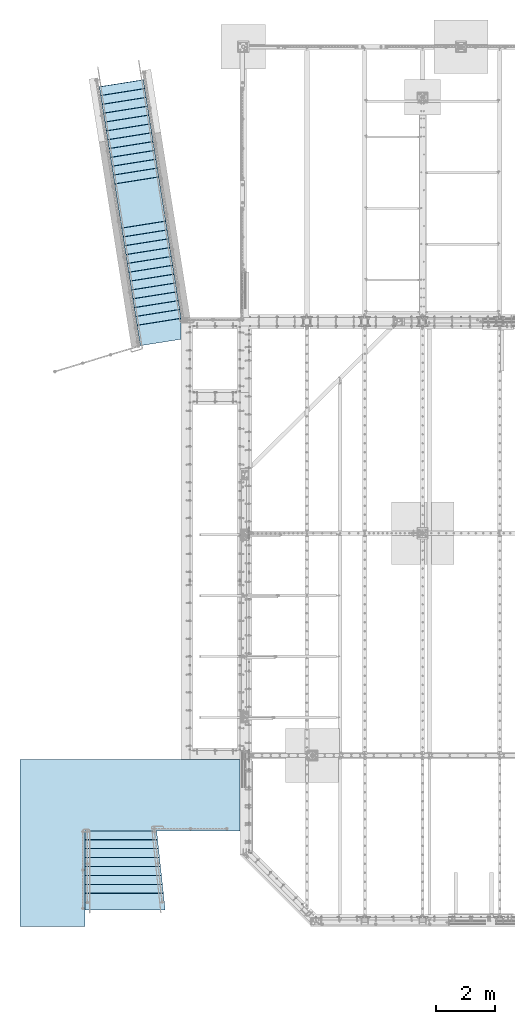
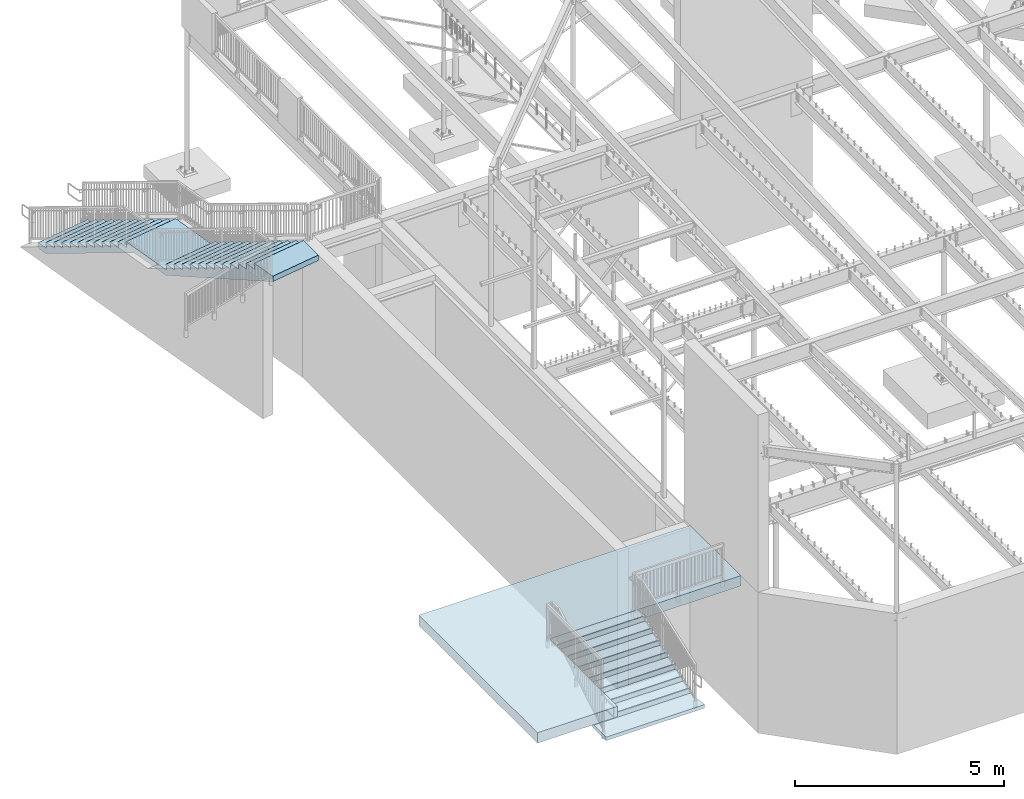
# One storey, part 829 of 975: 3 slabs.
"""IFC2X3 building model written with IfcOpenShell, lengths in millimetres."""

from ifc_helpers import new_model, si_unit, frame, origin_with_axes, place, context, subcontext, project, spatial, faceted_brep, material, type_object, element, save


model = new_model("IFC2X3")

# Units and contexts
model_context = context("Model", 3, precision=1e-05, world=origin_with_axes())
body_context = subcontext(model_context, "Body", "Model", "MODEL_VIEW")
ifc_project = project(units=[si_unit("LENGTHUNIT", "METRE", prefix="MILLI"), si_unit("AREAUNIT", "SQUARE_METRE"), si_unit("VOLUMEUNIT", "CUBIC_METRE"), si_unit("MASSUNIT", "GRAM", prefix="KILO"), si_unit("TIMEUNIT", "SECOND"), si_unit("PLANEANGLEUNIT", "RADIAN"), si_unit("SOLIDANGLEUNIT", "STERADIAN"), si_unit("THERMODYNAMICTEMPERATUREUNIT", "DEGREE_CELSIUS"), si_unit("LUMINOUSINTENSITYUNIT", "LUMEN")], contexts=[model_context])

# Site, building, storey
site_placement = place(None, origin_with_axes())
site = spatial("IfcSite", under=ifc_project, at=site_placement, CompositionType="ELEMENT")
building_placement = place(site_placement, origin_with_axes())
building = spatial("IfcBuilding", under=site, at=building_placement, Name="Undefined", CompositionType="ELEMENT")
storey_placement = place(building_placement, origin_with_axes())
storey = spatial("IfcBuildingStorey", under=building, at=storey_placement, Name="Undefined", CompositionType="ELEMENT", Elevation=0.0)

# Slabs
ifc_material = material(Name="CONCRETE/3000")
slab_type_1 = type_object("IfcSlabType", PredefinedType="NOTDEFINED")
slab_1_placement = place(storey_placement, frame((2016.12480603406, 3251.20039056697, 3962.39997558594), z_axis=(-0.999999999999998, 6.90000001668524e-08, 0.0), x_axis=(0.0, 1.0, 0.0)))
element("IfcSlab", 1, at=slab_1_placement, inside=storey, type_object=slab_type_1, material=ifc_material, Name="SLAB", PredefinedType="FLOOR", context=body_context, shape_type="Brep", body=[
    faceted_brep([(4.54747350886464e-13, -152.4, 2.27373675443232e-13), (-0.000227324977913668, -152.4, 2844.79980468751), (-0.000227324977913668, 152.4, 2844.79980468751), (4.54747350886464e-13, 152.4, 2.27373675443232e-13), (-0.000239550314290682, -152.4, 2911.74243164063), (-0.000239550314290682, 152.4, 2911.74243164063), (-0.000422655617057899, -152.4, 5283.19970703127), (-0.000422655617057899, 152.4, 5283.19970703127), (-3251.20092773405, -152.4, 5283.19921875022), (-3251.20092773405, 152.4, 5283.19921875022), (-3251.20092773391, -152.4, 7501.92285156273), (-3251.20092773391, 152.4, 7501.92285156273), (2424.57202148486, -152.4, 7501.92480468737), (2424.57202148486, 152.4, 7501.92480468737), (2424.57250976576, -152.4, 2016.12499999985), (2424.57250976576, 152.4, 2016.12499999985), (2425.69946289076, -152.4, 2016.12499999985), (2425.69946289076, 152.4, 2016.12499999985), (2425.69970703126, -152.4, -4.25188773078844e-10), (2425.69970703126, 152.4, -4.25188773078844e-10)], [[[0, 1, 2, 3]], [[1, 4, 5, 2]], [[4, 6, 7, 5]], [[6, 8, 9, 7]], [[8, 10, 11, 9]], [[10, 12, 13, 11]], [[12, 14, 15, 13]], [[14, 16, 17, 15]], [[16, 18, 19, 17]], [[18, 0, 3, 19]], [[5, 7, 9, 11, 13, 15, 17, 19, 3, 2]], [[18, 16, 14, 12, 10, 8, 6, 4, 1, 0]]]),
])
slab_type_2 = type_object("IfcSlabType", PredefinedType="NOTDEFINED")
slab_2_placement = place(storey_placement, frame((-1819.27499858123, 1143.00036444701, 2870.2), z_axis=(0.0, 0.0, -1.0), x_axis=(0.0, -1.0, 0.0)))
element("IfcSlab", 2, at=slab_2_placement, inside=storey, type_object=slab_type_2, material=ifc_material, Name="STAIR", PredefinedType="FLOOR", context=body_context, shape_type="Brep", body=[
    faceted_brep([(22.9399124926131, 1447.8, -168.686255001375), (20.3510419406048, 1447.8, -173.42106525441), (16.0299404980549, 1447.8, -176.653519614567), (10.7567768749961, 1447.8, -177.800003051758), (-304.799987792969, 1447.8, -177.800003051758), (-281.470857728083, 1447.8, -341.103955550173), (-281.860080640712, 1447.8, -346.486258341314), (-284.448951239109, 1447.8, -351.221068457464), (-288.770052641537, 1447.8, -354.453522707902), (-294.0432161735, 1447.8, -355.600006103516), (-609.599975585938, 1447.8, -355.600006103516), (-586.27087304912, 1447.8, -518.903976126535), (-586.660096770178, 1447.8, -524.286278298611), (-589.248967633653, 1447.8, -529.021087632559), (-593.570068806812, 1447.8, -532.253541256034), (-598.843231818224, 1447.8, -533.400024414062), (-914.400024414062, 1447.8, -533.400024414062), (-891.07086682111, 1447.8, -696.703959387874), (-891.46008892531, 1447.8, -702.086262798078), (-894.048959258629, 1447.8, -706.821073696431), (-898.370060890327, 1447.8, -710.053528573832), (-903.643224942838, 1447.8, -711.200012207031), (-1219.19995117188, 1447.8, -711.200012207031), (-1195.8709044884, 1447.8, -874.503955639886), (-1196.26012961073, 1447.8, -879.88625673892), (-1198.84900093367, 1447.8, -884.621064717048), (-1203.17010170943, 1447.8, -887.853517253785), (-1208.44326381856, 1447.8, -889.0), (-1524.0, 1447.8, -889.0), (-1500.67084160984, 1447.8, -1052.30399661319), (-1501.06006392962, 1447.8, -1057.68629985831), (-1503.64893433363, 1447.8, -1062.42111054807), (-1507.97003590419, 1447.8, -1065.65356525828), (-1513.24319981789, 1447.8, -1066.80004882812), (-1828.80004882812, 1447.8, -1066.80004882812), (-1805.47089287016, 1447.8, -1230.10391629805), (-1805.86011511785, 1447.8, -1235.48622109315), (-1808.44898668768, 1447.8, -1240.22103290149), (-1812.77009018458, 1447.8, -1243.45348760877), (-1818.04325599184, 1447.8, -1244.59996972142), (-2108.19995117188, 1447.8, -1244.59985351562), (-2108.19995117188, 1447.8, -1066.79992675781), (-2025.12231445312, 1447.8, -1066.80004882812), (-27.0423221588135, 1447.8, 101.599998474121), (583.815185546875, 1447.8, 101.599998474121), (583.815185546875, 1447.8, 0.0), (0.0, 1447.8, 0.0), (23.3291352637673, 1447.8, -163.303952101898), (583.815185546875, -1280.75730059277, 101.599998474121), (583.815185546875, -1280.75730059277, 0.0), (0.0, -1217.83111892056, 0.0), (23.3291352637673, -1220.34563625448, -163.303952101898), (22.9399124926131, -1220.3036841035, -168.686255001375), (20.3510419406048, -1220.02464419033, -173.42106525441), (16.0299404980549, -1219.5588967738, -176.653519614567), (10.7567768749961, -1218.99053188651, -177.800003051758), (-304.799987792969, -1184.97842875357, -177.800003051758), (-281.470857728083, -1187.49294552714, -341.103955550173), (-281.860080640712, -1187.45099336091, -346.486258341314), (-284.448951239109, -1187.17195344274, -351.221068457464), (-288.770052641537, -1186.70620603053, -354.453522707902), (-294.0432161735, -1186.13784115306, -355.600006103516), (-609.599975585938, -1152.12573858659, -355.600006103516), (-586.27087304912, -1154.64025239306, -518.903976126535), (-586.660096770178, -1154.59830013969, -524.286278298611), (-589.248967633653, -1154.31926019295, -529.021087632559), (-593.570068806812, -1153.85351280546, -532.253541256034), (-598.843231818224, -1153.2851479841, -533.400024414062), (-914.400024414062, -1119.27304184097, -533.400024414062), (-891.07086682111, -1121.78756158163, -696.703959387874), (-891.46008892531, -1121.74560950254, -702.086262798078), (-894.048959258629, -1121.46656961294, -706.821073696431), (-898.370060890327, -1121.00082217602, -710.053528573832), (-903.643224942838, -1120.43245724244, -711.200012207031), (-1219.19995117188, -1086.42035825263, -711.200012207031), (-1195.8709044884, -1088.93486603897, -874.503955639886), (-1196.26012961073, -1088.89291363457, -879.88625673892), (-1198.84900093367, -1088.61387363831, -884.621064717048), (-1203.17010170943, -1088.14812629365, -887.853517253785), (-1208.44326381856, -1087.57976156954, -889.0), (-1524.0, -1053.567661507, -889.0), (-1500.67084160984, -1056.08218133359, -1052.30399661319), (-1501.06006392962, -1056.04022923126, -1057.68629985831), (-1503.64893433363, -1055.76118933404, -1062.42111054807), (-1507.97003590419, -1055.29544190372, -1065.65356525828), (-1513.24319981789, -1054.7270769851, -1066.80004882812), (-1828.80004882812, -1020.71496476138, -1066.80004882812), (-1805.47089287016, -1023.22948432582, -1230.10391629805), (-1805.86011511785, -1023.18753223126, -1235.48622109315), (-1808.44898668768, -1022.90849220838, -1240.22103290149), (-1812.77009018458, -1022.44274457043, -1243.45348760877), (-1818.04325599184, -1021.87437944772, -1244.59996972142), (-2108.19995117188, -990.600008094722, -1244.59985351562), (-2108.19995117188, -990.600008094722, -1066.79992675781), (-2025.12231445312, -999.554483056119, -1066.80004882812), (-27.0423221588135, -1214.91637788755, 101.599998474121)], [[[0, 1, 2, 3, 4, 5, 6, 7, 8, 9, 10, 11, 12, 13, 14, 15, 16, 17, 18, 19, 20, 21, 22, 23, 24, 25, 26, 27, 28, 29, 30, 31, 32, 33, 34, 35, 36, 37, 38, 39, 40, 41, 42, 43, 44, 45, 46, 47]], [[45, 44, 48, 49]], [[46, 45, 49, 50]], [[47, 46, 50, 51]], [[0, 47, 51, 52]], [[1, 0, 52, 53]], [[2, 1, 53, 54]], [[3, 2, 54, 55]], [[4, 3, 55, 56]], [[5, 4, 56, 57]], [[6, 5, 57, 58]], [[7, 6, 58, 59]], [[8, 7, 59, 60]], [[9, 8, 60, 61]], [[10, 9, 61, 62]], [[11, 10, 62, 63]], [[12, 11, 63, 64]], [[13, 12, 64, 65]], [[14, 13, 65, 66]], [[15, 14, 66, 67]], [[16, 15, 67, 68]], [[17, 16, 68, 69]], [[18, 17, 69, 70]], [[19, 18, 70, 71]], [[20, 19, 71, 72]], [[21, 20, 72, 73]], [[22, 21, 73, 74]], [[23, 22, 74, 75]], [[24, 23, 75, 76]], [[25, 24, 76, 77]], [[26, 25, 77, 78]], [[27, 26, 78, 79]], [[28, 27, 79, 80]], [[29, 28, 80, 81]], [[30, 29, 81, 82]], [[31, 30, 82, 83]], [[32, 31, 83, 84]], [[33, 32, 84, 85]], [[34, 33, 85, 86]], [[35, 34, 86, 87]], [[36, 35, 87, 88]], [[37, 36, 88, 89]], [[38, 37, 89, 90]], [[39, 38, 90, 91]], [[40, 39, 91, 92]], [[41, 40, 92, 93]], [[42, 41, 93, 94]], [[43, 42, 94, 95]], [[44, 43, 95, 48]], [[94, 93, 92, 91, 90, 89, 88, 87, 86, 85, 84, 83, 82, 81, 80, 79, 78, 77, 76, 75, 74, 73, 72, 71, 70, 69, 68, 67, 66, 65, 64, 63, 62, 61, 60, 59, 58, 57, 56, 55, 54, 53, 52, 51, 50, 49, 48, 95]]]),
])
slab_type_3 = type_object("IfcSlabType", PredefinedType="NOTDEFINED")
slab_3_placement = place(storey_placement, frame((-747.347909321386, 20600.7344463593, 4038.60004696893), z_axis=(0.0, 0.0, -1.0), x_axis=(0.156434463962902, -0.98768834076577, 3.20000000030926e-08)))
element("IfcSlab", 3, at=slab_3_placement, inside=storey, type_object=slab_type_3, material=ifc_material, Name="STAIR", PredefinedType="FLOOR", context=body_context, shape_type="Brep", body=[
    faceted_brep([(-290.039056119542, -761.999999999877, 168.275023731918), (-295.335071312391, -761.999999999876, 169.431964500519), (-295.335071313042, 761.999999999946, 169.431964500588), (-290.0390561202, 761.999999999946, 168.275023731988), (-299.666176999308, -761.999999999875, 172.691997076068), (-299.666176999959, 761.999999999947, 172.691997076137), (-302.243265816895, -761.999999999875, 177.461158647158), (-302.243265817549, 761.999999999948, 177.461158647228), (-302.596804138157, -761.999999999875, 182.870530100508), (-302.596804138811, 761.999999999947, 182.870530100578), (-279.399932860801, -761.99999999989, 336.550018310512), (-279.399932861459, 761.999999999932, 336.550018310582), (-594.839201503801, -761.999999999839, 336.550018310512), (-594.839201504456, 761.999999999983, 336.550018310582), (-600.135215782844, -761.999999999839, 337.706958390595), (-600.135215783503, 761.999999999984, 337.706958390664), (-604.466321199499, -761.999999999838, 340.966989596354), (-604.466321200158, 761.999999999985, 340.966989596423), (-607.043410742303, -761.999999999838, 345.736149593788), (-607.043410742961, 761.999999999985, 345.736149593858), (-607.39695083223, -761.999999999839, 351.145519889634), (-607.396950832885, 761.999999999984, 351.145519889704), (-584.200134276565, -761.999999999852, 504.825042724575), (-584.20013427722, 761.99999999997, 504.825042724644), (-899.639057037857, -761.999999999802, 504.825042724575), (-899.639057038512, 762.000000000021, 504.825042724644), (-904.935073286422, -761.999999999801, 505.981983708286), (-904.935073287081, 762.000000000021, 505.981983708356), (-909.266179560127, -761.999999999801, 509.242017295658), (-909.266179560782, 762.000000000022, 509.242017295728), (-911.843268075008, -761.9999999998, 514.011180254855), (-911.843268075667, 762.000000000022, 514.011180254925), (-912.196805072606, -761.999999999801, 519.420552874324), (-912.196805073261, 762.000000000021, 519.420552874394), (-888.999877928654, -761.999999999815, 673.100097656215), (-888.999877929313, 762.000000000007, 673.100097656285), (-1204.43933901891, -761.999999999764, 673.100097656215), (-1204.43933901956, 762.000000000058, 673.100097656285), (-1209.73535739148, -761.999999999764, 674.257039614429), (-1209.73535739213, 762.000000000058, 674.257039614499), (-1214.06646458944, -761.999999999763, 677.517075770206), (-1214.06646459009, 762.000000000059, 677.517075770276), (-1216.64355199578, -761.999999999764, 682.28624192346), (-1216.64355199644, 762.000000000059, 682.28624192353), (-1216.99708565851, -761.999999999764, 687.695617048796), (-1216.99708565916, 762.000000000059, 687.695617048866), (-1193.80004882684, -761.999999999779, 841.375122070278), (-1193.8000488275, 762.000000000044, 841.375122070348), (-1509.23927476619, -761.999999999728, 841.375122070278), (-1509.23927476685, 762.000000000095, 841.375122070348), (-1514.53529140094, -761.999999999727, 842.532063231173), (-1514.5352914016, 762.000000000095, 842.532063231242), (-1518.86639784269, -761.999999999726, 845.792097285528), (-1518.86639784335, 762.000000000096, 845.792097285597), (-1521.44348615602, -761.999999999726, 850.561260825463), (-1521.44348615668, 762.000000000096, 850.561260825532), (-1521.79702254728, -761.999999999726, 855.970633900545), (-1521.79702254793, 762.000000000096, 855.970633900614), (-1498.60009765471, -761.999999999741, 1009.65002441403), (-1498.60009765537, 762.000000000081, 1009.6500244141), (-1814.03919093584, -761.99999999969, 1009.65002441403), (-1814.0391909365, 762.000000000132, 1009.6500244141), (-1819.33520961736, -761.999999999689, 1010.80696651399), (-1819.33520961801, 762.000000000133, 1010.80696651406), (-1823.66631694976, -761.999999999688, 1014.06700304335), (-1823.66631695041, 762.000000000133, 1014.06700304342), (-1826.24340419486, -761.999999999689, 1018.8361696612), (-1826.24340419551, 762.000000000133, 1018.83616966127), (-1826.59693737251, -761.999999999689, 1024.24554515103), (-1826.59693737316, 762.000000000133, 1024.2455451511), (-1803.39990234196, -761.999999999704, 1177.92492675778), (-1803.39990234261, 762.000000000119, 1177.92492675785), (-2118.83903957283, -761.999999999653, 1177.92492675778), (-2118.83903957349, 762.000000000169, 1177.92492675785), (-2124.13504975835, -761.999999999652, 1179.08186495973), (-2124.13504975901, 762.000000000171, 1179.0818649598), (-2128.4661533937, -761.999999999652, 1182.34189121547), (-2128.46615339435, 762.000000000171, 1182.34189121554), (-2131.04324507295, -761.999999999651, 1187.11104505708), (-2131.04324507361, 762.000000000171, 1187.11104505715), (-2131.39679159006, -761.999999999652, 1192.52041052343), (-2131.39679159072, 762.00000000017, 1192.5204105235), (-2108.20019531046, -761.999999999666, 1346.19995117184), (-2108.20019531111, 762.000000000156, 1346.19995117191), (-2423.63906722494, -761.999999999615, 1346.19995117184), (-2423.63906722559, 762.000000000207, 1346.19995117191), (-2428.93508150398, -761.999999999615, 1347.35689125192), (-2428.93508150463, 762.000000000207, 1347.35689125199), (-2433.26618692063, -761.999999999614, 1350.61692245768), (-2433.26618692129, 762.000000000208, 1350.61692245775), (-2435.84327646344, -761.999999999614, 1355.38608245512), (-2435.8432764641, 762.000000000209, 1355.38608245519), (-2436.19681655337, -761.999999999615, 1360.79545275096), (-2436.19681655402, 762.000000000208, 1360.79545275103), (-2412.9999999977, -761.999999999628, 1514.4749755859), (-2412.99999999836, 762.000000000194, 1514.47497558597), (-2728.43909487702, -761.999999999578, 1514.4749755859), (-2728.43909487767, 762.000000000244, 1514.47497558597), (-2733.73511324958, -761.999999999578, 1515.63191754412), (-2733.73511325024, 762.000000000245, 1515.63191754419), (-2738.06622044755, -761.999999999577, 1518.89195369989), (-2738.06622044821, 762.000000000245, 1518.89195369996), (-2740.64330785389, -761.999999999577, 1523.66111985315), (-2740.64330785455, 762.000000000245, 1523.66111985322), (-2740.99684151661, -761.999999999577, 1529.07049497848), (-2740.99684151727, 762.000000000245, 1529.07049497855), (-2717.79980468495, -761.999999999592, 1682.74999999997), (-2717.7998046856, 762.000000000231, 1682.75000000004), (-3033.23918997698, -761.999999999541, 1682.75011661342), (-3033.23918997763, 762.000000000281, 1682.75011661349), (-3038.5351989769, -761.99999999954, 1683.90705642551), (-3038.53519897756, 762.000000000282, 1683.90705642558), (-3042.86630107726, -761.999999999539, 1687.16708336594), (-3042.86630107792, 762.000000000283, 1687.16708336601), (-3045.44339138898, -761.99999999954, 1691.93623702056), (-3045.44339138963, 762.000000000282, 1691.93623702063), (-3045.79693709626, -761.999999999539, 1697.34560172346), (-3045.79693709692, 762.000000000283, 1697.34560172353), (-3022.60034179407, -761.999999999554, 1851.02502441403), (-3022.60034179472, 762.000000000268, 1851.0250244141), (-3338.03892881451, -761.999999999504, 1851.02502441403), (-3338.03892881517, 762.000000000319, 1851.0250244141), (-3343.33495097165, -761.999999999503, 1852.18196810862), (-3343.33495097231, 762.00000000032, 1852.18196810869), (-3347.66605981649, -761.999999999503, 1855.44200884083), (-3347.66605981715, 762.00000000032, 1855.4420088409), (-3350.24314524761, -761.999999999503, 1860.2111806853), (-3350.24314524827, 762.00000000032, 1860.21118068537), (-3350.5966729682, -761.999999999503, 1865.62056027563), (-3350.59667296886, 762.000000000319, 1865.62056027569), (-3327.39941405944, -761.999999999517, 2019.3001708984), (-3327.3994140601, 762.000000000305, 2019.30017089847), (-4862.03892444059, -761.99999999927, 2019.30004999103), (-4862.03892444125, 762.000000000552, 2019.3000499911), (-4867.33494753414, -761.99999999927, 2020.45699365618), (-4867.3349475348, 762.000000000553, 2020.45699365625), (-4871.66605700362, -761.999999999269, 2023.71703506927), (-4871.66605700428, 762.000000000553, 2023.71703506934), (-4874.24314236933, -761.999999999269, 2028.4862079818), (-4874.24314236999, 762.000000000553, 2028.48620798187), (-4874.59666918898, -761.99999999927, 2033.89558854149), (-4874.59666918964, 762.000000000553, 2033.89558854156), (-4851.39941405803, -761.999999999283, 2187.57495117184), (-4851.39941405869, 762.000000000539, 2187.57495117191), (-5166.83873030395, -761.999999999233, 2187.57495117184), (-5166.83873030461, 762.000000000589, 2187.57495117191), (-5172.13475307899, -761.999999999232, 2188.73189514993), (-5172.13475307965, 762.00000000059, 2188.73189515), (-5176.4658621927, -761.999999999231, 2191.99193662932), (-5176.46586219336, 762.00000000059, 2191.99193662939), (-5179.04294730133, -761.999999999232, 2196.76110940299), (-5179.04294730199, 762.000000000591, 2196.76110940306), (-5179.39647405177, -761.999999999232, 2202.1704897223), (-5179.39647405242, 762.00000000059, 2202.17048972237), (-5156.19921874528, -761.999999999247, 2355.84985351559), (-5156.19921874594, 762.000000000576, 2355.84985351566), (-5471.63858053918, -761.999999999196, 2355.84985351559), (-5471.63858053984, 762.000000000627, 2355.84985351566), (-5476.93459450928, -761.999999999195, 2357.00679345393), (-5476.93459450993, 762.000000000627, 2357.006793454), (-5481.2656997915, -761.999999999195, 2360.2668242861), (-5481.26569979216, 762.000000000628, 2360.26682428617), (-5483.84278949555, -761.999999999195, 2365.03598381895), (-5483.8427894962, 762.000000000628, 2365.03598381902), (-5484.19633007054, -761.999999999194, 2370.44535375031), (-5484.19633007119, 762.000000000628, 2370.44535375038), (-5460.99951171378, -761.99999999921, 2524.12499999997), (-5460.99951171444, 762.000000000613, 2524.12500000004), (-5776.43887031134, -761.999999999158, 2524.12499999997), (-5776.438870312, 762.000000000664, 2524.12500000004), (-5781.73488489933, -761.999999999158, 2525.28194022179), (-5781.73488489999, 762.000000000665, 2525.28194022186), (-5786.06599045042, -761.999999999157, 2528.54197180114), (-5786.06599045108, 762.000000000665, 2528.54197180121), (-5788.64307983199, -761.999999999158, 2533.31113226316), (-5788.64307983264, 762.000000000665, 2533.31113226323), (-5788.99661943685, -761.999999999158, 2538.72050292349), (-5788.9966194375, 762.000000000664, 2538.72050292356), (-5765.79980468228, -761.999999999171, 2692.39990234372), (-5765.79980468293, 762.000000000651, 2692.39990234379), (-6081.23867819492, -761.999999999122, 2692.39990234372), (-6081.23867819558, 762.000000000701, 2692.39990234379), (-6086.53469216502, -761.999999999121, 2693.55684228205), (-6086.53469216568, 762.000000000701, 2693.55684228212), (-6090.86579744724, -761.99999999912, 2696.81687311423), (-6090.8657974479, 762.000000000703, 2696.8168731143), (-6093.44288715129, -761.999999999119, 2701.58603264707), (-6093.44288715194, 762.000000000703, 2701.58603264714), (-6093.79642772628, -761.99999999912, 2706.99540257843), (-6093.79642772693, 762.000000000703, 2706.9954025785), (-6070.59960936952, -761.999999999135, 2860.67504882809), (-6070.59960937018, 762.000000000688, 2860.67504882816), (-6386.03896796709, -761.999999999084, 2860.67504882809), (-6386.03896796774, 762.000000000738, 2860.67504882816), (-6391.33498255507, -761.999999999083, 2861.83198904992), (-6391.33498255573, 762.000000000739, 2861.83198904999), (-6395.66608810617, -761.999999999082, 2865.09202062926), (-6395.66608810682, 762.000000000739, 2865.09202062933), (-6398.24317748773, -761.999999999082, 2869.86118109129), (-6398.24317748839, 762.000000000739, 2869.86118109136), (-6398.59671709258, -761.999999999083, 2875.27055175162), (-6398.59671709324, 762.00000000074, 2875.27055175169), (-6375.39990233802, -761.999999999097, 3028.94995117184), (-6375.39990233868, 762.000000000725, 3028.94995117191), (-6690.83873030269, -761.999999999047, 3028.94995117184), (-6690.83873030335, 762.000000000776, 3028.94995117191), (-6696.13475307773, -761.999999999046, 3030.10689514993), (-6696.13475307839, 762.000000000776, 3030.10689515), (-6700.46586219143, -761.999999999045, 3033.36693662932), (-6700.46586219209, 762.000000000777, 3033.36693662939), (-6703.04294730006, -761.999999999045, 3038.13610940299), (-6703.04294730071, 762.000000000777, 3038.13610940306), (-6703.3964740505, -761.999999999045, 3043.5454897223), (-6703.39647405116, 762.000000000777, 3043.54548972237), (-6680.19921874401, -761.99999999906, 3197.22485351559), (-6680.19921874467, 762.000000000762, 3197.22485351566), (-6995.63858053791, -761.999999999009, 3197.22485351559), (-6995.63858053857, 762.000000000813, 3197.22485351566), (-7000.93459450801, -761.999999999009, 3198.38179345393), (-7000.93459450867, 762.000000000813, 3198.381793454), (-7005.26569979023, -761.999999999008, 3201.6418242861), (-7005.26569979089, 762.000000000814, 3201.64182428617), (-7007.84278949428, -761.999999999009, 3206.41098381895), (-7007.84278949493, 762.000000000814, 3206.41098381902), (-7008.19633006927, -761.999999999009, 3211.82035375031), (-7008.19633006992, 762.000000000814, 3211.82035375038), (-6984.99951171251, -761.999999999023, 3365.49999999997), (-6984.99951171317, 762.000000000799, 3365.50000000004), (-7300.43887031008, -761.999999998972, 3365.49999999997), (-7300.43887031074, 762.00000000085, 3365.50000000004), (-7305.73488489807, -761.999999998972, 3366.65694022179), (-7305.73488489872, 762.00000000085, 3366.65694022186), (-7310.06599044916, -761.999999998971, 3369.91697180114), (-7310.06599044982, 762.000000000851, 3369.91697180121), (-7312.64307983072, -761.99999999897, 3374.68613226316), (-7312.64307983137, 762.000000000852, 3374.68613226323), (-7312.99661943557, -761.999999998971, 3380.0955029235), (-7312.99661943623, 762.000000000851, 3380.09550292356), (-7289.79980468101, -761.999999998985, 3533.77490234372), (-7289.79980468166, 762.000000000837, 3533.77490234379), (-7605.23867819365, -761.999999998934, 3533.77490234372), (-7605.23867819431, 762.000000000887, 3533.77490234379), (-7610.53469216375, -761.999999998934, 3534.93184228205), (-7610.53469216441, 762.000000000889, 3534.93184228212), (-7614.86579744597, -761.999999998934, 3538.19187311423), (-7614.86579744663, 762.000000000889, 3538.1918731143), (-7617.44288715002, -761.999999998934, 3542.96103264707), (-7617.44288715068, 762.000000000889, 3542.96103264714), (-7617.79642772501, -761.999999998934, 3548.37040257843), (-7617.79642772567, 762.000000000888, 3548.3704025785), (-7594.59960936826, -761.999999998948, 3702.05004882809), (-7594.59960936891, 762.000000000874, 3702.05004882816), (-7910.03896796582, -761.999999998898, 3702.05004882809), (-7910.03896796648, 762.000000000924, 3702.05004882816), (-7915.33498255381, -761.999999998897, 3703.20698904992), (-7915.33498255446, 762.000000000926, 3703.20698904999), (-7919.6660881049, -761.999999998896, 3706.46702062926), (-7919.66608810555, 762.000000000927, 3706.46702062933), (-7922.24317748646, -761.999999998897, 3711.23618109129), (-7922.24317748712, 762.000000000926, 3711.23618109136), (-7922.59671709132, -761.999999998897, 3716.64555175162), (-7922.59671709198, 762.000000000926, 3716.64555175169), (-7899.39990233675, -761.999999998911, 3870.32495117184), (-7899.39990233741, 762.000000000912, 3870.32495117191), (-8214.83881500461, -761.99999999886, 3870.32495117184), (-8214.83881500526, 762.000000000963, 3870.32495117191), (-8220.13482140554, -761.999999998859, 3871.4818876374), (-8220.13482140619, 762.000000000963, 3871.48188763747), (-8224.465923394, -761.999999998859, 3874.74190931671), (-8224.46592339466, 762.000000000963, 3874.74190931678), (-8227.04301704848, -761.999999998859, 3879.51105746707), (-8227.04301704913, 762.000000000963, 3879.51105746714), (-8227.39656950769, -761.999999998859, 3884.92041846839), (-8227.39656950835, 762.000000000963, 3884.92041846846), (-8204.20019530525, -761.999999998874, 4038.59985351559), (-8204.2001953059, 762.000000000949, 4038.59985351566), (-7924.80908202426, -761.999999998919, 4038.60009765622), (-7924.80908202492, 762.000000000904, 4038.60009765629), (-7877.54589843055, -761.999999998924, 4012.50683593747), (-7877.54589843121, 762.000000000898, 4012.50683593754), (-7741.19238280566, -761.999999998941, 3937.22827148434), (-7741.19238280632, 762.000000000881, 3937.22827148441), (-4572.00927733955, -761.999999999328, 2187.57495117184), (-4572.0092773402, 762.000000000493, 2187.57495117191), (-3352.79980468445, -761.999999999525, 2187.52661132809), (-3352.79980468511, 762.000000000297, 2187.52661132816), (711.199951170845, 761.999999999786, 159.86320495609), (711.199951170875, 761.999999999797, -1.09048414742574e-09), (14.7608442494056, 761.999999999908, 1.18234311230481e-11), (9.46482820480378, 761.99999999991, 1.15694089015506), (5.13372201985476, 761.99999999991, 4.41697423090272), (2.55663339852981, 761.99999999991, 9.18613688339474), (2.20309608071693, 761.99999999991, 14.5955092622394), (25.4000053401905, 761.999999999896, 168.275009155308), (711.199951171449, -644.02069718213, 159.863204956025), (711.199951171482, -644.020697497916, -1.15505827125162e-09), (14.7608442500605, -754.325805498939, -5.77529135625809e-11), (9.46482820545134, -755.1646119565, 1.15694089008548), (5.13372202050959, -755.85059171591, 4.41697423083315), (2.55663339918465, -756.258762407816, 9.18613688332516), (2.20309608136813, -756.314757202184, 14.5955092621703), (25.4000053408454, -752.64072774699, 168.275009155239), (-33.6921194699426, -761.999999999918, 168.275011885931), (-33.6921240004558, -761.999999999943, 531.51440900601)], [[[0, 1, 2, 3]], [[1, 4, 5, 2]], [[4, 6, 7, 5]], [[6, 8, 9, 7]], [[8, 10, 11, 9]], [[10, 12, 13, 11]], [[12, 14, 15, 13]], [[14, 16, 17, 15]], [[16, 18, 19, 17]], [[18, 20, 21, 19]], [[20, 22, 23, 21]], [[22, 24, 25, 23]], [[24, 26, 27, 25]], [[26, 28, 29, 27]], [[28, 30, 31, 29]], [[30, 32, 33, 31]], [[32, 34, 35, 33]], [[34, 36, 37, 35]], [[36, 38, 39, 37]], [[38, 40, 41, 39]], [[40, 42, 43, 41]], [[42, 44, 45, 43]], [[44, 46, 47, 45]], [[46, 48, 49, 47]], [[48, 50, 51, 49]], [[50, 52, 53, 51]], [[52, 54, 55, 53]], [[54, 56, 57, 55]], [[56, 58, 59, 57]], [[58, 60, 61, 59]], [[60, 62, 63, 61]], [[62, 64, 65, 63]], [[64, 66, 67, 65]], [[66, 68, 69, 67]], [[68, 70, 71, 69]], [[70, 72, 73, 71]], [[72, 74, 75, 73]], [[74, 76, 77, 75]], [[76, 78, 79, 77]], [[78, 80, 81, 79]], [[80, 82, 83, 81]], [[82, 84, 85, 83]], [[84, 86, 87, 85]], [[86, 88, 89, 87]], [[88, 90, 91, 89]], [[90, 92, 93, 91]], [[92, 94, 95, 93]], [[94, 96, 97, 95]], [[96, 98, 99, 97]], [[98, 100, 101, 99]], [[100, 102, 103, 101]], [[102, 104, 105, 103]], [[104, 106, 107, 105]], [[106, 108, 109, 107]], [[108, 110, 111, 109]], [[110, 112, 113, 111]], [[112, 114, 115, 113]], [[114, 116, 117, 115]], [[116, 118, 119, 117]], [[118, 120, 121, 119]], [[120, 122, 123, 121]], [[122, 124, 125, 123]], [[124, 126, 127, 125]], [[126, 128, 129, 127]], [[128, 130, 131, 129]], [[130, 132, 133, 131]], [[132, 134, 135, 133]], [[134, 136, 137, 135]], [[136, 138, 139, 137]], [[138, 140, 141, 139]], [[140, 142, 143, 141]], [[142, 144, 145, 143]], [[144, 146, 147, 145]], [[146, 148, 149, 147]], [[148, 150, 151, 149]], [[150, 152, 153, 151]], [[152, 154, 155, 153]], [[154, 156, 157, 155]], [[156, 158, 159, 157]], [[158, 160, 161, 159]], [[160, 162, 163, 161]], [[162, 164, 165, 163]], [[164, 166, 167, 165]], [[166, 168, 169, 167]], [[168, 170, 171, 169]], [[170, 172, 173, 171]], [[172, 174, 175, 173]], [[174, 176, 177, 175]], [[176, 178, 179, 177]], [[178, 180, 181, 179]], [[180, 182, 183, 181]], [[182, 184, 185, 183]], [[184, 186, 187, 185]], [[186, 188, 189, 187]], [[188, 190, 191, 189]], [[190, 192, 193, 191]], [[192, 194, 195, 193]], [[194, 196, 197, 195]], [[196, 198, 199, 197]], [[198, 200, 201, 199]], [[200, 202, 203, 201]], [[202, 204, 205, 203]], [[204, 206, 207, 205]], [[206, 208, 209, 207]], [[208, 210, 211, 209]], [[210, 212, 213, 211]], [[212, 214, 215, 213]], [[214, 216, 217, 215]], [[216, 218, 219, 217]], [[218, 220, 221, 219]], [[220, 222, 223, 221]], [[222, 224, 225, 223]], [[224, 226, 227, 225]], [[226, 228, 229, 227]], [[228, 230, 231, 229]], [[230, 232, 233, 231]], [[232, 234, 235, 233]], [[234, 236, 237, 235]], [[236, 238, 239, 237]], [[238, 240, 241, 239]], [[240, 242, 243, 241]], [[242, 244, 245, 243]], [[244, 246, 247, 245]], [[246, 248, 249, 247]], [[248, 250, 251, 249]], [[250, 252, 253, 251]], [[252, 254, 255, 253]], [[254, 256, 257, 255]], [[256, 258, 259, 257]], [[258, 260, 261, 259]], [[260, 262, 263, 261]], [[262, 264, 265, 263]], [[264, 266, 267, 265]], [[266, 268, 269, 267]], [[268, 270, 271, 269]], [[270, 272, 273, 271]], [[272, 274, 275, 273]], [[274, 276, 277, 275]], [[276, 278, 279, 277]], [[278, 280, 281, 279]], [[280, 282, 283, 281]], [[282, 284, 285, 283]], [[3, 2, 5, 7, 9, 11, 13, 15, 17, 19, 21, 23, 25, 27, 29, 31, 33, 35, 37, 39, 41, 43, 45, 47, 49, 51, 53, 55, 57, 59, 61, 63, 65, 67, 69, 71, 73, 75, 77, 79, 81, 83, 85, 87, 89, 91, 93, 95, 97, 99, 101, 103, 105, 107, 109, 111, 113, 115, 117, 119, 121, 123, 125, 127, 129, 131, 133, 135, 137, 139, 141, 143, 145, 147, 149, 151, 153, 155, 157, 159, 161, 163, 165, 167, 169, 171, 173, 175, 177, 179, 181, 183, 185, 187, 189, 191, 193, 195, 197, 199, 201, 203, 205, 207, 209, 211, 213, 215, 217, 219, 221, 223, 225, 227, 229, 231, 233, 235, 237, 239, 241, 243, 245, 247, 249, 251, 253, 255, 257, 259, 261, 263, 265, 267, 269, 271, 273, 275, 277, 279, 281, 283, 285, 286, 287, 288, 289, 290, 291, 292, 293]], [[287, 286, 294, 295]], [[288, 287, 295, 296]], [[289, 288, 296, 297]], [[290, 289, 297, 298]], [[291, 290, 298, 299]], [[292, 291, 299, 300]], [[293, 292, 300, 301]], [[0, 3, 293, 301, 302]], [[284, 282, 280, 278, 276, 274, 272, 270, 268, 266, 264, 262, 260, 258, 256, 254, 252, 250, 248, 246, 244, 242, 240, 238, 236, 234, 232, 230, 228, 226, 224, 222, 220, 218, 216, 214, 212, 210, 208, 206, 204, 202, 200, 198, 196, 194, 192, 190, 188, 186, 184, 182, 180, 178, 176, 174, 172, 170, 168, 166, 164, 162, 160, 158, 156, 154, 152, 150, 148, 146, 144, 142, 140, 138, 136, 134, 132, 130, 128, 126, 124, 122, 120, 118, 116, 114, 112, 110, 108, 106, 104, 102, 100, 98, 96, 94, 92, 90, 88, 86, 84, 82, 80, 78, 76, 74, 72, 70, 68, 66, 64, 62, 60, 58, 56, 54, 52, 50, 48, 46, 44, 42, 40, 38, 36, 34, 32, 30, 28, 26, 24, 22, 20, 18, 16, 14, 12, 10, 8, 6, 4, 1, 0, 302, 303]], [[286, 285, 284, 303, 294]], [[302, 301, 300, 299, 298, 297, 296, 295, 294, 303]]]),
])

save(model, "model.ifc")
